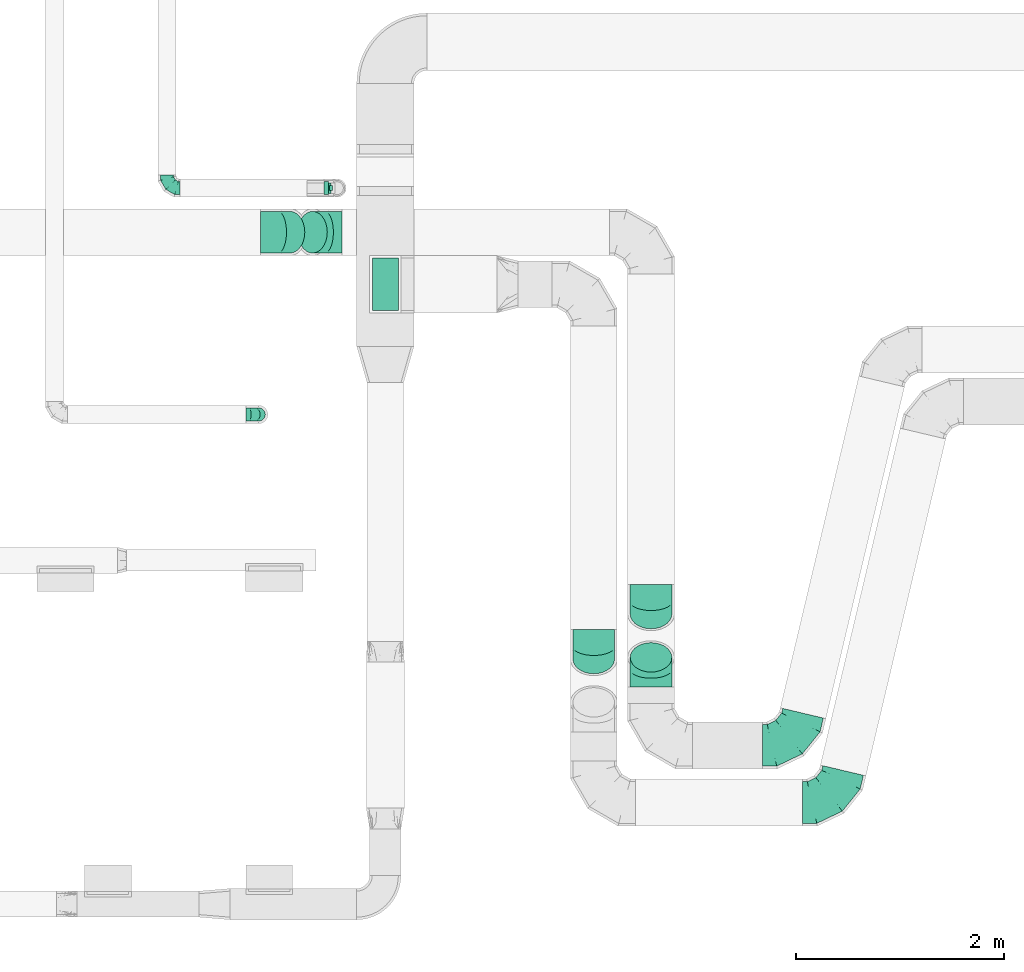
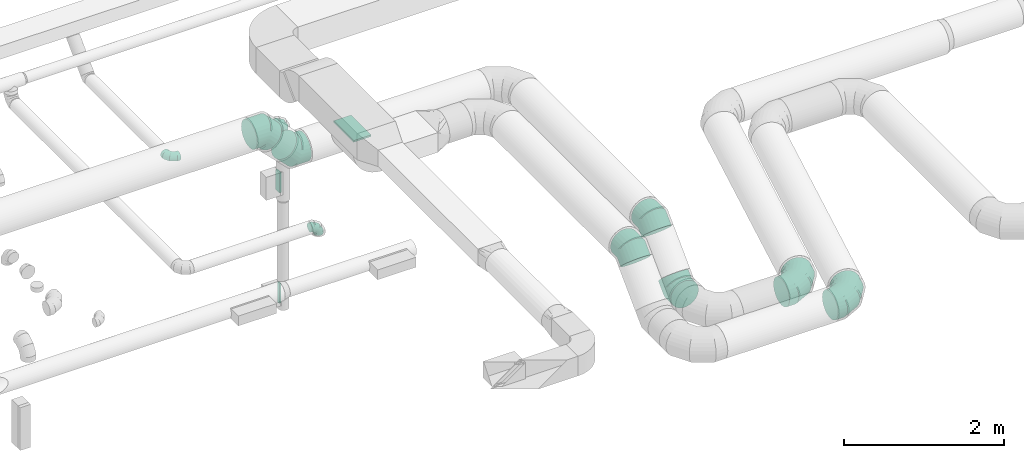
# One storey, part 53 of 97: 13 flow fittings.
"""IFC2X3 building model written with IfcOpenShell, lengths in millimetres."""

import ifcopenshell
import ifcopenshell.guid

model = None  # the IFC model being written
_history = None  # IfcOwnerHistory: only IFC2X3 demands one
_inside = {}  # id of a spatial element -> (the spatial element, [elements in it])
_under = {}  # id of a project, library or spatial element -> (it, [spatial elements below it])
_declared = {}  # id of a project -> (the project, [libraries it declares])
_typed = {}  # id of a type object -> (the type object, [elements of that type])
_made_of = {}  # id of a material, layer set ... -> (it, [elements and type objects made of it])


def new_model(schema):
    """Start an empty IFC model of exactly this schema.

    Asked for "IFC4X3", IfcOpenShell would pick the latest addendum, in which some entities
    have other attributes; the version numbers below select the first issue.
    IFC2X3 requires an IfcOwnerHistory on every rooted entity: one is made here for all.
    """
    global model, _history
    if schema == "IFC4X3":
        model = ifcopenshell.file(schema_version=(4, 3, 0, 0))
    else:
        model = ifcopenshell.file(schema=schema)
    _inside.clear()
    _under.clear()
    _declared.clear()
    _typed.clear()
    _made_of.clear()
    _history = None
    if model.schema == "IFC2X3":
        org = make("IfcOrganization", Name="unknown")
        user = make(
            "IfcPersonAndOrganization",
            ThePerson=make("IfcPerson", FamilyName="unknown"),
            TheOrganization=org,
        )
        app = make(
            "IfcApplication",
            ApplicationDeveloper=org,
            Version="unknown",
            ApplicationFullName="unknown",
            ApplicationIdentifier="unknown",
        )
        _history = make(
            "IfcOwnerHistory",
            OwningUser=user,
            OwningApplication=app,
            ChangeAction="ADDED",
            CreationDate=0,
        )
    return model


def make(cls, **values):
    """One entity of the class cls with the attributes given. An attribute that is None is left unset."""
    return model.create_entity(
        cls, **{name: value for name, value in values.items() if value is not None}
    )


def entity(cls, *values):
    """Any entity or typed value of the class cls, its attributes in the order of the schema. None: left unset."""
    e = model.create_entity(cls)
    for i, value in enumerate(values):
        if value is not None:
            e[i] = value
    return e


def rooted(cls, **values):
    """An entity with a GlobalId (a new one), such as an element, a storey or a relation."""
    return make(cls, GlobalId=ifcopenshell.guid.new(), OwnerHistory=_history, **values)


def si_unit(unit_type, name, prefix=None):
    """IfcSIUnit, for example si_unit("LENGTHUNIT", "METRE", prefix="MILLI")."""
    return make("IfcSIUnit", UnitType=unit_type, Prefix=prefix, Name=name)


def converted_unit(unit_type, name, factor, base, dimensions=None, offset=None):
    """IfcConversionBasedUnit, such as the inch: factor (a typed value) times the base unit."""
    return make(
        "IfcConversionBasedUnit"
        if offset is None
        else "IfcConversionBasedUnitWithOffset",
        ConversionOffset=offset,
        Dimensions=None
        if dimensions is None
        else entity("IfcDimensionalExponents", *dimensions),
        UnitType=unit_type,
        Name=name,
        ConversionFactor=make(
            "IfcMeasureWithUnit", ValueComponent=factor, UnitComponent=base
        ),
    )


def derived_unit(unit_type, elements):
    """IfcDerivedUnit: a product of units, each with its exponent."""
    return make(
        "IfcDerivedUnit",
        Elements=[
            make("IfcDerivedUnitElement", Unit=unit, Exponent=power)
            for unit, power in elements
        ],
        UnitType=unit_type,
    )


def assignment(units):
    """IfcUnitAssignment: the units of a project."""
    return None if units is None else make("IfcUnitAssignment", Units=units)


def point(xyz):
    """IfcCartesianPoint."""
    return None if xyz is None else make("IfcCartesianPoint", Coordinates=xyz)


def direction(xyz):
    """IfcDirection."""
    return None if xyz is None else make("IfcDirection", DirectionRatios=xyz)


def frame(location, z_axis=None, x_axis=None):
    """IfcAxis2Placement3D, a coordinate frame: its origin and axes. An axis left out is left unset."""
    return make(
        "IfcAxis2Placement3D",
        Location=point(location),
        Axis=direction(z_axis),
        RefDirection=direction(x_axis),
    )


def frame_2d(location, x_axis=None):
    """IfcAxis2Placement2D, a coordinate frame in the plane: its origin and x axis."""
    return make(
        "IfcAxis2Placement2D", Location=point(location), RefDirection=direction(x_axis)
    )


def origin():
    """The frame at (0, 0, 0) with its axes left unset."""
    return frame((0.0, 0.0, 0.0))


def origin_2d_with_axis():
    """The frame at (0, 0) in the plane with the x axis (1, 0) written out."""
    return frame_2d((0.0, 0.0), x_axis=(1.0, 0.0))


def place(relative_to, where):
    """IfcLocalPlacement: puts the frame where relative to a parent placement (None: the world)."""
    return make(
        "IfcLocalPlacement", PlacementRelTo=relative_to, RelativePlacement=where
    )


def context(
    kind, dimensions, precision=None, world=None, true_north=None, identifier=None
):
    """IfcGeometricRepresentationContext, for example the 3D "Model" context."""
    return make(
        "IfcGeometricRepresentationContext",
        ContextIdentifier=identifier,
        ContextType=kind,
        CoordinateSpaceDimension=dimensions,
        Precision=precision,
        WorldCoordinateSystem=world,
        TrueNorth=true_north,
    )


def subcontext(parent, identifier, kind, view, scale=None):
    """IfcGeometricRepresentationSubContext, for example "Body" below "Model"."""
    return make(
        "IfcGeometricRepresentationSubContext",
        ContextIdentifier=identifier,
        ContextType=kind,
        ParentContext=parent,
        TargetScale=scale,
        TargetView=view,
    )


def project(units=None, contexts=None):
    """IfcProject with its units and contexts."""
    return rooted(
        "IfcProject",
        Name="project",
        RepresentationContexts=contexts,
        UnitsInContext=assignment(units),
    )


def spatial(cls, under=None, at=None, **own):
    """A site, building, storey or space (cls), placed at a placement, below another one or the project."""
    s = rooted(cls, ObjectPlacement=at, **own)
    if under is not None:
        _under.setdefault(under.id(), (under, []))[1].append(s)
    return s


def profile(cls, at=None, kind="AREA", **sizes):
    """A parametric profile (cls). Its sizes go by their IFC names, for example OverallWidth=200.0."""
    return make(cls, ProfileType=kind, Position=at, **sizes)


def rectangle(**sizes):
    """IfcRectangleProfileDef."""
    return profile("IfcRectangleProfileDef", **sizes)


def extrude(swept, where, along, depth):
    """IfcExtrudedAreaSolid: the profile swept, set in the frame where, extruded along a direction by depth."""
    return make(
        "IfcExtrudedAreaSolid",
        SweptArea=swept,
        Position=where,
        ExtrudedDirection=direction(along),
        Depth=depth,
    )


def faces_of(points, faces, orient=None, outer=None):
    """IfcFace entities. A face is a list of loops; a loop is a list of indices into points, from 0.

    orient and outer hold one flag for each loop. By default every Orientation is true, the
    first loop of a face is its IfcFaceOuterBound and the others are IfcFaceBound.
    """
    made = []
    for i, loops in enumerate(faces):
        bounds = []
        for j, loop in enumerate(loops):
            is_outer = j == 0 if outer is None else outer[i][j]
            bounds.append(
                make(
                    "IfcFaceOuterBound" if is_outer else "IfcFaceBound",
                    Bound=make("IfcPolyLoop", Polygon=[points[k] for k in loop]),
                    Orientation=True if orient is None else orient[i][j],
                )
            )
        made.append(make("IfcFace", Bounds=bounds))
    return made


def faceted_brep(points, faces, orient=None, outer=None, voids=None):
    """IfcFacetedBrep: a solid bounded by flat faces; with voids (closed shells), ...WithVoids."""
    shared = [point(p) for p in points]
    hull = make("IfcClosedShell", CfsFaces=faces_of(shared, faces, orient, outer))
    if voids is None:
        return make("IfcFacetedBrep", Outer=hull)
    return make(
        "IfcFacetedBrepWithVoids",
        Outer=hull,
        Voids=[
            make(cls, CfsFaces=faces_of(shared, fs, o, b)) for cls, fs, o, b in voids
        ],
    )


def shape(context_of_items, identifier, shape_type, items):
    """IfcShapeRepresentation: the items that make up one representation, for example the "Body"."""
    return make(
        "IfcShapeRepresentation",
        ContextOfItems=context_of_items,
        RepresentationIdentifier=identifier,
        RepresentationType=shape_type,
        Items=items,
    )


def source(mapping_origin, context_of_items, identifier, shape_type, items):
    """IfcRepresentationMap: a shape defined once, which mapped items show again and again."""
    return make(
        "IfcRepresentationMap",
        MappingOrigin=mapping_origin,
        MappedRepresentation=shape(context_of_items, identifier, shape_type, items),
    )


def transform(
    local_origin,
    x_axis=None,
    y_axis=None,
    z_axis=None,
    scale=None,
    scale2=None,
    scale3=None,
    uniform=True,
):
    """IfcCartesianTransformationOperator3D, or its non-uniform kind. x_axis, y_axis, z_axis: its Axis1, 2, 3."""
    if uniform:
        return make(
            "IfcCartesianTransformationOperator3D",
            Axis1=direction(x_axis),
            Axis2=direction(y_axis),
            LocalOrigin=point(local_origin),
            Scale=scale,
            Axis3=direction(z_axis),
        )
    return make(
        "IfcCartesianTransformationOperator3DnonUniform",
        Axis1=direction(x_axis),
        Axis2=direction(y_axis),
        LocalOrigin=point(local_origin),
        Scale=scale,
        Axis3=direction(z_axis),
        Scale2=scale2,
        Scale3=scale3,
    )


def mapped(mapping_source, mapping_target):
    """IfcMappedItem: shows the shape of a source again, moved by a transform."""
    return make(
        "IfcMappedItem", MappingSource=mapping_source, MappingTarget=mapping_target
    )


def material(Name=None, Category=None):
    """IfcMaterial."""
    return make("IfcMaterial", Name=Name, Category=Category)


def made_of(thing, what):
    """Note that an element or type object is made of a material, layer set ...; save() writes the relation."""
    if what is not None:
        _made_of.setdefault(what.id(), (what, []))[1].append(thing)
    return thing


def type_object(cls, material=None, **own):
    """A type object (cls), such as IfcWallType, which elements share."""
    return made_of(rooted(cls, **own), material)


def type_shapes(of_type, sources):
    """Give a type object the sources (RepresentationMaps) that its elements show as mapped items."""
    of_type.RepresentationMaps = sources


def element(
    cls,
    number,
    at=None,
    inside=None,
    cuts=None,
    type_object=None,
    material=None,
    context=None,
    identifier="Body",
    shape_type=None,
    held_by="IfcProductDefinitionShape",
    body=None,
    shapes=None,
    **own,
):
    """One element of the class cls, such as IfcWall. Its Tag is "e" and its number.

    at: its placement. inside: the storey or other place that contains it. cuts: it is an
    opening in that element (IfcRelVoidsElement). A single representation is given by context,
    identifier, shape_type and body (its items); several are given by shapes. held_by: the class
    of the entity that holds the representations. save() writes the other relations.
    """
    e = rooted(cls, Tag="e%d" % number, ObjectPlacement=at, **own)
    if body is not None:
        shapes = [shape(context, identifier, shape_type, body)]
    if shapes is not None:
        e.Representation = make(held_by, Representations=shapes)
    if inside is not None:
        _inside.setdefault(inside.id(), (inside, []))[1].append(e)
    if cuts is not None:
        rooted(
            "IfcRelVoidsElement", RelatingBuildingElement=cuts, RelatedOpeningElement=e
        )
    if type_object is not None:
        _typed.setdefault(type_object.id(), (type_object, []))[1].append(e)
    return made_of(e, material)


def aggregate(whole, parts):
    """IfcRelAggregates: a whole, such as a stair, and the parts it consists of."""
    return rooted("IfcRelAggregates", RelatingObject=whole, RelatedObjects=parts)


def save(model, path):
    """Write the relations noted so far, then the file.

    IfcRelAggregates (storeys below a building ...), IfcRelContainedInSpatialStructure (elements
    in a storey), IfcRelDefinesByType, IfcRelAssociatesMaterial and IfcRelDeclares: one each for
    every whole, place, type object, material and project.
    """
    for whole, parts in _under.values():
        aggregate(whole, parts)
    for where, things in _inside.values():
        rooted(
            "IfcRelContainedInSpatialStructure",
            RelatedElements=things,
            RelatingStructure=where,
        )
    for kind, things in _typed.values():
        rooted("IfcRelDefinesByType", RelatedObjects=things, RelatingType=kind)
    for what, things in _made_of.values():
        rooted("IfcRelAssociatesMaterial", RelatedObjects=things, RelatingMaterial=what)
    for by, libraries in _declared.values():
        rooted("IfcRelDeclares", RelatingContext=by, RelatedDefinitions=libraries)
    model.write(path)


model = new_model("IFC2X3")

# Units and contexts
model_context = context("Model", 3, precision=0.01, world=origin(), true_north=direction((6.12303176911189e-17, 1.0)))
body_context = subcontext(model_context, "Body", "Model", "MODEL_VIEW")
ifc_project = project(units=[si_unit("LENGTHUNIT", "METRE", prefix="MILLI"), si_unit("AREAUNIT", "SQUARE_METRE"), si_unit("VOLUMEUNIT", "CUBIC_METRE"), converted_unit("PLANEANGLEUNIT", "DEGREE", entity("IfcRatioMeasure", 0.0174532925199433), si_unit("PLANEANGLEUNIT", "RADIAN"), dimensions=[0, 0, 0, 0, 0, 0, 0]), si_unit("MASSUNIT", "GRAM", prefix="KILO"), derived_unit("MASSDENSITYUNIT", [(si_unit("MASSUNIT", "GRAM", prefix="KILO"), 1), (si_unit("LENGTHUNIT", "METRE"), -3)]), derived_unit("MOMENTOFINERTIAUNIT", [(si_unit("LENGTHUNIT", "METRE"), 4)]), si_unit("TIMEUNIT", "SECOND"), si_unit("FREQUENCYUNIT", "HERTZ"), si_unit("THERMODYNAMICTEMPERATUREUNIT", "DEGREE_CELSIUS"), derived_unit("THERMALTRANSMITTANCEUNIT", [(si_unit("MASSUNIT", "GRAM", prefix="KILO"), 1), (si_unit("THERMODYNAMICTEMPERATUREUNIT", "KELVIN"), -1), (si_unit("TIMEUNIT", "SECOND"), -3)]), derived_unit("VOLUMETRICFLOWRATEUNIT", [(si_unit("LENGTHUNIT", "METRE"), 3), (si_unit("TIMEUNIT", "SECOND"), -1)]), derived_unit("MASSFLOWRATEUNIT", [(si_unit("MASSUNIT", "GRAM", prefix="KILO"), 1), (si_unit("TIMEUNIT", "SECOND"), -1)]), derived_unit("ROTATIONALFREQUENCYUNIT", [(si_unit("TIMEUNIT", "SECOND"), -1)]), si_unit("ELECTRICCURRENTUNIT", "AMPERE"), si_unit("ELECTRICVOLTAGEUNIT", "VOLT"), si_unit("POWERUNIT", "WATT"), si_unit("FORCEUNIT", "NEWTON", prefix="KILO"), si_unit("ILLUMINANCEUNIT", "LUX"), si_unit("LUMINOUSFLUXUNIT", "LUMEN"), si_unit("LUMINOUSINTENSITYUNIT", "CANDELA"), derived_unit("USERDEFINED", [(si_unit("MASSUNIT", "GRAM", prefix="KILO"), -1), (si_unit("LENGTHUNIT", "METRE"), -2), (si_unit("TIMEUNIT", "SECOND"), 3), (si_unit("LUMINOUSFLUXUNIT", "LUMEN"), 1)]), derived_unit("LINEARVELOCITYUNIT", [(si_unit("LENGTHUNIT", "METRE"), 1), (si_unit("TIMEUNIT", "SECOND"), -1)]), si_unit("PRESSUREUNIT", "PASCAL"), derived_unit("USERDEFINED", [(si_unit("LENGTHUNIT", "METRE"), -2), (si_unit("MASSUNIT", "GRAM", prefix="KILO"), 1), (si_unit("TIMEUNIT", "SECOND"), -2)]), derived_unit("LINEARFORCEUNIT", [(si_unit("MASSUNIT", "GRAM", prefix="KILO"), 1), (si_unit("LENGTHUNIT", "METRE"), 1), (si_unit("TIMEUNIT", "SECOND"), -2), (si_unit("LENGTHUNIT", "METRE"), -1)]), derived_unit("PLANARFORCEUNIT", [(si_unit("MASSUNIT", "GRAM", prefix="KILO"), 1), (si_unit("LENGTHUNIT", "METRE"), 1), (si_unit("TIMEUNIT", "SECOND"), -2), (si_unit("LENGTHUNIT", "METRE"), -2)])], contexts=[model_context])

# Site, building, storey
site_placement = place(None, origin())
site = spatial("IfcSite", under=ifc_project, at=site_placement, CompositionType="ELEMENT")
building_placement = place(site_placement, origin())
building = spatial("IfcBuilding", under=site, at=building_placement, CompositionType="ELEMENT")
storey_placement = place(building_placement, frame((0.0, 0.0, -4900.0)))
storey = spatial("IfcBuildingStorey", under=building, at=storey_placement, CompositionType="ELEMENT", Elevation=-4900.0)

# Flow fittings
ifc_material = material()
duct_fitting_type_1 = type_object("IfcDuctFittingType", PredefinedType="NOTDEFINED", material=ifc_material)
shared_shape_1 = source(origin(), body_context, "Body", "SweptSolid", [
    extrude(rectangle(XDim=26.0960000001476, YDim=300.0, at=origin_2d_with_axis()), frame((6.95, 0.0, -50.0)), (0.0, 0.0, 1.0), 100.0),
])
type_shapes(duct_fitting_type_1, [shared_shape_1])
flow_fitting_1_placement = place(storey_placement, frame((48936.88, 7146.24, 2850.0), z_axis=(0.0, 1.0, 0.0), x_axis=(-1.0, 0.0, 0.0)))
element("IfcFlowFitting", 1, at=flow_fitting_1_placement, inside=storey, type_object=duct_fitting_type_1, material=ifc_material, context=body_context, shape_type="MappedRepresentation", body=[
    mapped(shared_shape_1, transform((0.0, 0.0, 0.0), scale=1.0)),
])
duct_fitting_type_2 = type_object("IfcDuctFittingType", PredefinedType="NOTDEFINED", material=ifc_material)
shared_shape_2 = source(origin(), body_context, "Body", "SweptSolid", [
    extrude(rectangle(XDim=250.0, YDim=26.0960000001597, at=origin_2d_with_axis()), frame((6.95, 0.0, -250.0), z_axis=(0.0, 0.0, 1.0), x_axis=(0.0, -1.0, 0.0)), (0.0, 0.0, 1.0), 500.0),
])
type_shapes(duct_fitting_type_2, [shared_shape_2])
flow_fitting_2_placement = place(storey_placement, frame((49463.6, 6223.55, 4025.0), z_axis=(0.0, -1.0, 0.0), x_axis=(0.0, 0.0, -1.0)))
element("IfcFlowFitting", 2, at=flow_fitting_2_placement, inside=storey, type_object=duct_fitting_type_2, material=ifc_material, context=body_context, shape_type="MappedRepresentation", body=[
    mapped(shared_shape_2, transform((0.0, 0.0, 0.0), scale=1.0)),
])
duct_fitting_type_3 = type_object("IfcDuctFittingType", PredefinedType="NOTDEFINED", material=ifc_material)
shared_shape_3 = source(origin(), body_context, "Body", "SweptSolid", [
    extrude(rectangle(XDim=26.0960000000091, YDim=300.0, at=origin_2d_with_axis()), frame((6.95, 0.0, -25.0)), (0.0, 0.0, 1.0), 50.0),
])
type_shapes(duct_fitting_type_3, [shared_shape_3])
flow_fitting_3_placement = place(storey_placement, frame((48949.38, 7146.24, 1150.0), z_axis=(0.0, 1.0, 0.0), x_axis=(-1.0, 0.0, 0.0)))
element("IfcFlowFitting", 3, at=flow_fitting_3_placement, inside=storey, type_object=duct_fitting_type_3, material=ifc_material, context=body_context, shape_type="MappedRepresentation", body=[
    mapped(shared_shape_3, transform((0.0, 0.0, 0.0), scale=1.0)),
])
duct_fitting_type_4 = type_object("IfcDuctFittingType", PredefinedType="NOTDEFINED", material=ifc_material)
shared_shape_4 = source(origin(), body_context, "Body", "Brep", [
    faceted_brep([(-125.0, 0.0, -62.5), (-125.0, -16.18, -60.37), (-125.0, -31.25, -54.13), (-125.0, -44.19, -44.19), (-125.0, -54.13, -31.25), (-125.0, -60.37, -16.18), (-125.0, -62.5, 0.0), (-125.0, -60.37, 16.18), (-125.0, -54.13, 31.25), (-125.0, -44.19, 44.19), (-125.0, -31.25, 54.13), (-125.0, -16.18, 60.37), (-125.0, 0.0, 62.5), (-125.0, 16.18, 60.37), (-125.0, 31.25, 54.13), (-125.0, 44.19, 44.19), (-125.0, 54.13, 31.25), (-125.0, 60.37, 16.18), (-125.0, 62.5, 0.0), (-125.0, 60.37, -16.18), (-125.0, 54.13, -31.25), (-125.0, 44.19, -44.19), (-125.0, 31.25, -54.13), (-125.0, 16.18, -60.37), (-95.84, 16.18, 60.37), (-99.88, 31.25, 54.13), (-91.51, 0.0, 62.5), (-103.35, 44.19, 44.19), (-107.68, 60.37, 16.18), (-108.25, 62.5, 0.0), (-106.01, 54.13, 31.25), (-106.01, 54.13, -31.25), (-103.35, 44.19, -44.19), (-107.68, 60.37, -16.18), (-95.84, 16.18, -60.37), (-91.51, 0.0, -62.5), (-99.88, 31.25, -54.13), (-87.17, -16.18, -60.37), (-83.13, -31.25, -54.13), (-79.66, -44.19, -44.19), (-77.0, -54.13, -31.25), (-75.33, -60.37, -16.18), (-74.76, -62.5, 0.0), (-75.33, -60.37, 16.18), (-77.0, -54.13, 31.25), (-79.66, -44.19, 44.19), (-83.13, -31.25, 54.13), (-87.17, -16.18, 60.37), (-45.34, 45.34, 60.37), (-56.37, 56.37, 54.13), (-33.49, 33.49, 62.5), (-65.85, 65.85, 44.19), (-73.12, 73.12, 31.25), (-77.69, 77.69, 16.18), (-79.25, 79.25, 0.0), (-77.69, 77.69, -16.18), (-73.12, 73.12, -31.25), (-65.85, 65.85, -44.19), (-45.34, 45.34, -60.37), (-33.49, 33.49, -62.5), (-56.37, 56.37, -54.13), (-21.65, 21.65, -60.37), (-10.62, 10.62, -54.13), (-1.14, 1.14, -44.19), (6.13, -6.13, -31.25), (10.7, -10.7, -16.18), (12.26, -12.26, 0.0), (10.7, -10.7, 16.18), (6.13, -6.13, 31.25), (-1.14, 1.14, 44.19), (-10.62, 10.62, 54.13), (-21.65, 21.65, 60.37), (-16.18, 95.84, 60.37), (-31.25, 99.88, 54.13), (0.0, 91.51, 62.5), (-44.19, 103.35, 44.19), (-54.13, 106.01, 31.25), (-60.37, 107.68, 16.18), (-62.5, 108.25, 0.0), (-60.37, 107.68, -16.18), (-54.13, 106.01, -31.25), (-44.19, 103.35, -44.19), (-16.18, 95.84, -60.37), (0.0, 91.51, -62.5), (-31.25, 99.88, -54.13), (16.18, 87.17, -60.37), (31.25, 83.13, -54.13), (44.19, 79.66, -44.19), (54.13, 77.0, -31.25), (60.37, 75.33, -16.18), (62.5, 74.76, 0.0), (60.37, 75.33, 16.18), (54.13, 77.0, 31.25), (44.19, 79.66, 44.19), (31.25, 83.13, 54.13), (16.18, 87.17, 60.37), (-16.18, 125.0, -60.37), (-31.25, 125.0, -54.13), (-44.19, 125.0, -44.19), (-54.13, 125.0, -31.25), (-60.37, 125.0, -16.18), (-62.5, 125.0, 0.0), (-60.37, 125.0, 16.18), (-54.13, 125.0, 31.25), (-44.19, 125.0, 44.19), (-31.25, 125.0, 54.13), (-16.18, 125.0, 60.37), (0.0, 125.0, 62.5), (16.18, 125.0, 60.37), (31.25, 125.0, 54.13), (44.19, 125.0, 44.19), (54.13, 125.0, 31.25), (60.37, 125.0, 16.18), (62.5, 125.0, 0.0), (60.37, 125.0, -16.18), (54.13, 125.0, -31.25), (44.19, 125.0, -44.19), (31.25, 125.0, -54.13), (16.18, 125.0, -60.37), (0.0, 125.0, -62.5)], [[[0, 1, 2, 3, 4, 5, 6, 7, 8, 9, 10, 11, 12, 13, 14, 15, 16, 17, 18, 19, 20, 21, 22, 23]], [[24, 25, 14, 13]], [[26, 24, 13, 12]], [[14, 25, 27, 15]], [[28, 29, 18, 17]], [[30, 28, 17, 16]], [[15, 27, 30, 16]], [[20, 31, 32, 21]], [[33, 31, 20, 19]], [[18, 29, 33, 19]], [[34, 35, 0, 23]], [[36, 34, 23, 22]], [[21, 32, 36, 22]], [[1, 0, 35, 37]], [[2, 1, 37, 38]], [[38, 39, 3, 2]], [[5, 4, 40, 41]], [[6, 5, 41, 42]], [[39, 40, 4, 3]], [[6, 42, 43, 7]], [[7, 43, 44, 8]], [[45, 9, 8, 44]], [[9, 45, 46, 10]], [[10, 46, 47, 11]], [[26, 12, 11, 47]], [[48, 49, 25, 24]], [[50, 48, 24, 26]], [[27, 25, 49, 51]], [[52, 53, 28, 30]], [[51, 52, 30, 27]], [[29, 28, 53, 54]], [[55, 56, 31, 33]], [[54, 55, 33, 29]], [[57, 32, 31, 56]], [[58, 59, 35, 34]], [[60, 58, 34, 36]], [[57, 60, 36, 32]], [[37, 35, 59, 61]], [[38, 37, 61, 62]], [[39, 38, 62, 63]], [[41, 40, 64, 65]], [[42, 41, 65, 66]], [[63, 64, 40, 39]], [[43, 42, 66, 67]], [[44, 43, 67, 68]], [[68, 69, 45, 44]], [[46, 45, 69, 70]], [[47, 46, 70, 71]], [[26, 47, 71, 50]], [[72, 73, 49, 48]], [[74, 72, 48, 50]], [[51, 49, 73, 75]], [[76, 77, 53, 52]], [[75, 76, 52, 51]], [[54, 53, 77, 78]], [[79, 80, 56, 55]], [[78, 79, 55, 54]], [[81, 57, 56, 80]], [[82, 83, 59, 58]], [[84, 82, 58, 60]], [[81, 84, 60, 57]], [[61, 59, 83, 85]], [[62, 61, 85, 86]], [[63, 62, 86, 87]], [[65, 64, 88, 89]], [[66, 65, 89, 90]], [[87, 88, 64, 63]], [[67, 66, 90, 91]], [[68, 67, 91, 92]], [[92, 93, 69, 68]], [[70, 69, 93, 94]], [[71, 70, 94, 95]], [[50, 71, 95, 74]], [[96, 97, 98, 99, 100, 101, 102, 103, 104, 105, 106, 107, 108, 109, 110, 111, 112, 113, 114, 115, 116, 117, 118, 119]], [[72, 74, 107, 106]], [[73, 72, 106, 105]], [[75, 73, 105, 104]], [[77, 76, 103, 102]], [[78, 77, 102, 101]], [[75, 104, 103, 76]], [[78, 101, 100, 79]], [[79, 100, 99, 80]], [[80, 99, 98, 81]], [[96, 119, 83, 82]], [[97, 96, 82, 84]], [[84, 81, 98, 97]], [[83, 119, 118, 85]], [[85, 118, 117, 86]], [[116, 87, 86, 117]], [[88, 115, 114, 89]], [[89, 114, 113, 90]], [[115, 88, 87, 116]], [[91, 90, 113, 112]], [[92, 91, 112, 111]], [[111, 110, 93, 92]], [[95, 94, 109, 108]], [[74, 95, 108, 107]], [[110, 109, 94, 93]]]),
])
type_shapes(duct_fitting_type_4, [shared_shape_4])
for number, where, z_axis, x_axis in (
    (4, (48999.38, 7146.24, 3740.0), (0.0, 1.0, 0.0), (1.0, 0.0, 0.0)),
    (5, (48249.39, 4973.33, 3740.0), (0.0, -1.0, 0.0), (0.0, 0.0, 1.0)),
    (6, (47368.94, 7146.24, 3740.0), (0.0, 0.0, 1.0), (0.0, -1.0, 0.0)),
):
    element("IfcFlowFitting", number, at=place(storey_placement, frame(where, z_axis=z_axis, x_axis=x_axis)), inside=storey, type_object=duct_fitting_type_4, material=ifc_material, context=body_context, shape_type="MappedRepresentation", body=[
        mapped(shared_shape_4, transform((0.0, 0.0, 0.0), scale=1.0)),
    ])
duct_fitting_type_5 = type_object("IfcDuctFittingType", PredefinedType="NOTDEFINED", material=ifc_material)
shared_shape_5 = source(origin(), body_context, "Body", "Brep", [
    faceted_brep([(-165.69, 0.0, -200.0), (-165.69, -44.5, -194.99), (-165.69, -86.78, -180.19), (-165.69, -124.7, -156.37), (-165.69, -156.37, -124.7), (-165.69, -180.19, -86.78), (-165.69, -194.99, -44.5), (-165.69, -200.0, 0.0), (-165.69, -194.99, 44.5), (-165.69, -180.19, 86.78), (-165.69, -156.37, 124.7), (-165.69, -124.7, 156.37), (-165.69, -86.78, 180.19), (-165.69, -44.5, 194.99), (-165.69, 0.0, 200.0), (-165.69, 44.5, 194.99), (-165.69, 86.78, 180.19), (-165.69, 124.7, 156.37), (-165.69, 156.37, 124.7), (-165.69, 180.19, 86.78), (-165.69, 194.99, 44.5), (-165.69, 200.0, 0.0), (-165.69, 194.99, -44.5), (-165.69, 180.19, -86.78), (-165.69, 156.37, -124.7), (-165.69, 124.7, -156.37), (-165.69, 86.78, -180.19), (-165.69, 44.5, -194.99), (0.0, 0.0, 200.0), (-18.43, 44.5, 194.99), (-35.94, 86.78, 180.19), (-51.65, 124.7, 156.37), (-64.77, 156.37, 124.7), (-74.64, 180.19, 86.78), (-80.77, 194.99, 44.5), (-82.84, 200.0, 0.0), (-80.77, 194.99, -44.5), (-74.64, 180.19, -86.78), (-64.77, 156.37, -124.7), (-51.65, 124.7, -156.37), (-35.94, 86.78, -180.19), (-18.43, 44.5, -194.99), (0.0, 0.0, -200.0), (18.43, -44.5, -194.99), (35.94, -86.78, -180.19), (51.65, -124.7, -156.37), (64.77, -156.37, -124.7), (74.64, -180.19, -86.78), (80.77, -194.99, -44.5), (82.84, -200.0, 0.0), (80.77, -194.99, 44.5), (74.64, -180.19, 86.78), (64.77, -156.37, 124.7), (51.65, -124.7, 156.37), (35.94, -86.78, 180.19), (18.43, -44.5, 194.99), (117.16, 117.16, 200.0), (85.69, 148.63, 194.99), (55.8, 178.52, 180.19), (28.98, 205.33, 156.37), (6.59, 227.72, 124.7), (-10.26, 244.57, 86.78), (-20.72, 255.03, 44.5), (-24.26, 258.58, 0.0), (-20.72, 255.03, -44.5), (-10.26, 244.57, -86.78), (6.59, 227.72, -124.7), (28.98, 205.33, -156.37), (55.8, 178.52, -180.19), (85.69, 148.63, -194.99), (117.16, 117.16, -200.0), (148.63, 85.69, -194.99), (178.52, 55.8, -180.19), (205.33, 28.98, -156.37), (227.72, 6.59, -124.7), (244.57, -10.26, -86.78), (255.03, -20.72, -44.5), (258.58, -24.26, 0.0), (255.03, -20.72, 44.5), (244.57, -10.26, 86.78), (227.72, 6.59, 124.7), (205.33, 28.98, 156.37), (178.52, 55.8, 180.19), (148.63, 85.69, 194.99)], [[[0, 1, 2, 3, 4, 5, 6, 7, 8, 9, 10, 11, 12, 13, 14, 15, 16, 17, 18, 19, 20, 21, 22, 23, 24, 25, 26, 27]], [[28, 29, 15, 14]], [[30, 31, 17, 16]], [[29, 30, 16, 15]], [[31, 32, 18, 17]], [[32, 33, 19, 18]], [[34, 35, 21, 20]], [[33, 34, 20, 19]], [[35, 36, 22, 21]], [[37, 38, 24, 23]], [[36, 37, 23, 22]], [[38, 39, 25, 24]], [[39, 40, 26, 25]], [[41, 42, 0, 27]], [[40, 41, 27, 26]], [[1, 0, 42, 43]], [[43, 44, 2, 1]], [[45, 3, 2, 44]], [[45, 46, 4, 3]], [[5, 4, 46, 47]], [[47, 48, 6, 5]], [[49, 7, 6, 48]], [[7, 49, 50, 8]], [[8, 50, 51, 9]], [[9, 51, 52, 10]], [[52, 53, 11, 10]], [[11, 53, 54, 12]], [[12, 54, 55, 13]], [[13, 55, 28, 14]], [[29, 28, 56, 57]], [[30, 29, 57, 58]], [[31, 30, 58, 59]], [[59, 60, 32, 31]], [[33, 32, 60, 61]], [[34, 33, 61, 62]], [[35, 34, 62, 63]], [[63, 64, 36, 35]], [[65, 66, 38, 37]], [[64, 65, 37, 36]], [[66, 67, 39, 38]], [[39, 67, 68, 40]], [[40, 68, 69, 41]], [[41, 69, 70, 42]], [[42, 70, 71, 43]], [[43, 71, 72, 44]], [[44, 72, 73, 45]], [[73, 74, 46, 45]], [[46, 74, 75, 47]], [[47, 75, 76, 48]], [[48, 76, 77, 49]], [[50, 49, 77, 78]], [[51, 50, 78, 79]], [[52, 51, 79, 80]], [[80, 81, 53, 52]], [[54, 53, 81, 82]], [[55, 54, 82, 83]], [[28, 55, 83, 56]], [[69, 68, 67, 66, 65, 64, 63, 62, 61, 60, 59, 58, 57, 56, 83, 82, 81, 80, 79, 78, 77, 76, 75, 74, 73, 72, 71, 70]]]),
])
type_shapes(duct_fitting_type_5, [shared_shape_5])
for number, where, z_axis, x_axis in (
    (7, (52014.1, 3175.13, 3600.0), (1.0, 0.0, 0.0), (0.0, -1.0, 0.0)),
    (8, (52014.1, 2525.13, 2950.0), (-1.0, 0.0, 0.0), (0.0, -0.707106781186522, -0.707106781186573)),
    (9, (51464.16, 2743.55, 3600.0), (1.0, 0.0, 0.0), (0.0, -1.0, 0.0)),
    (10, (48432.38, 6723.09, 4050.0), (0.0, 1.0, 0.0), (1.0, 0.0, 0.0)),
    (11, (48882.38, 6723.09, 3600.0), (0.0, -1.0, 0.0), (0.707106781186526, 0.0, -0.707106781186569)),
):
    element("IfcFlowFitting", number, at=place(storey_placement, frame(where, z_axis=z_axis, x_axis=x_axis)), inside=storey, type_object=duct_fitting_type_5, material=ifc_material, context=body_context, shape_type="MappedRepresentation", body=[
        mapped(shared_shape_5, transform((0.0, 0.0, 0.0), scale=1.0)),
    ])
duct_fitting_type_6 = type_object("IfcDuctFittingType", PredefinedType="NOTDEFINED", material=ifc_material)
shared_shape_6 = source(origin(), body_context, "Body", "Brep", [
    faceted_brep([(-316.33, 0.0, -200.0), (-316.33, -44.5, -194.99), (-316.33, -86.78, -180.19), (-316.33, -124.7, -156.37), (-316.33, -156.37, -124.7), (-316.33, -180.19, -86.78), (-316.33, -194.99, -44.5), (-316.33, -200.0, 0.0), (-316.33, -194.99, 44.5), (-316.33, -180.19, 86.78), (-316.33, -156.37, 124.7), (-316.33, -124.7, 156.37), (-316.33, -86.78, 180.19), (-316.33, -44.5, 194.99), (-316.33, 0.0, 200.0), (-316.33, 44.5, 194.99), (-316.33, 86.78, 180.19), (-316.33, 124.7, 156.37), (-316.33, 156.37, 124.7), (-316.33, 180.19, 86.78), (-316.33, 194.99, 44.5), (-316.33, 200.0, 0.0), (-316.33, 194.99, -44.5), (-316.33, 180.19, -86.78), (-316.33, 156.37, -124.7), (-316.33, 124.7, -156.37), (-316.33, 86.78, -180.19), (-316.33, 44.5, -194.99), (-225.6, 0.0, 200.0), (-235.7, 44.5, 194.99), (-245.29, 86.78, 180.19), (-253.89, 124.7, 156.37), (-261.07, 156.37, 124.7), (-266.47, 180.19, 86.78), (-269.83, 194.99, 44.5), (-270.97, 200.0, 0.0), (-269.83, 194.99, -44.5), (-266.47, 180.19, -86.78), (-261.07, 156.37, -124.7), (-253.89, 124.7, -156.37), (-245.29, 86.78, -180.19), (-235.7, 44.5, -194.99), (-225.6, 0.0, -200.0), (-215.51, -44.5, -194.99), (-205.92, -86.78, -180.19), (-197.32, -124.7, -156.37), (-190.14, -156.37, -124.7), (-184.73, -180.19, -86.78), (-181.38, -194.99, -44.5), (-180.24, -200.0, 0.0), (-181.38, -194.99, 44.5), (-184.73, -180.19, 86.78), (-190.14, -156.37, 124.7), (-197.32, -124.7, 156.37), (-205.92, -86.78, 180.19), (-215.51, -44.5, 194.99), (-61.91, 78.28, 200.0), (-90.22, 114.08, 194.99), (-117.1, 148.08, 180.19), (-141.22, 178.58, 156.37), (-161.37, 204.05, 124.7), (-176.52, 223.21, 86.78), (-185.93, 235.11, 44.5), (-189.12, 239.14, 0.0), (-185.93, 235.11, -44.5), (-176.52, 223.21, -86.78), (-161.37, 204.05, -124.7), (-141.22, 178.58, -156.37), (-117.1, 148.08, -180.19), (-90.22, 114.08, -194.99), (-61.91, 78.28, -200.0), (-33.6, 42.49, -194.99), (-6.71, 8.49, -180.19), (17.41, -22.01, -156.37), (37.55, -47.48, -124.7), (52.7, -66.64, -86.78), (62.11, -78.54, -44.5), (65.3, -82.57, 0.0), (62.11, -78.54, 44.5), (52.7, -66.64, 86.78), (37.55, -47.48, 124.7), (17.41, -22.01, 156.37), (-6.71, 8.49, 180.19), (-33.6, 42.49, 194.99), (51.99, 219.53, 200.0), (11.01, 239.61, 194.99), (-27.91, 258.68, 180.19), (-62.83, 275.79, 156.37), (-91.99, 290.08, 124.7), (-113.93, 300.83, 86.78), (-127.55, 307.5, 44.5), (-132.17, 309.77, 0.0), (-127.55, 307.5, -44.5), (-113.93, 300.83, -86.78), (-91.99, 290.08, -124.7), (-62.83, 275.79, -156.37), (-27.91, 258.68, -180.19), (11.01, 239.61, -194.99), (51.99, 219.53, -200.0), (92.97, 199.45, -194.99), (131.9, 180.38, -180.19), (166.82, 163.27, -156.37), (195.98, 148.98, -124.7), (217.92, 138.23, -86.78), (231.54, 131.56, -44.5), (236.16, 129.3, 0.0), (231.54, 131.56, 44.5), (217.92, 138.23, 86.78), (195.98, 148.98, 124.7), (166.82, 163.27, 156.37), (131.9, 180.38, 180.19), (92.97, 199.45, 194.99), (-121.71, 353.91, 0.0), (-116.83, 352.75, 44.5), (-102.44, 349.34, 86.78), (-79.25, 343.85, 124.7), (-48.44, 336.55, 156.37), (-11.54, 327.81, 180.19), (29.6, 318.07, 194.99), (72.9, 307.81, 200.0), (116.21, 297.56, 194.99), (157.34, 287.81, 180.19), (194.24, 279.07, 156.37), (225.06, 271.78, 124.7), (248.25, 266.28, 86.78), (262.64, 262.88, 44.5), (267.52, 261.72, 0.0), (262.64, 262.88, -44.5), (248.25, 266.28, -86.78), (225.06, 271.78, -124.7), (194.24, 279.07, -156.37), (157.34, 287.81, -180.19), (116.21, 297.56, -194.99), (72.9, 307.81, -200.0), (29.6, 318.07, -194.99), (-11.54, 327.81, -180.19), (-48.44, 336.55, -156.37), (-79.25, 343.85, -124.7), (-102.44, 349.34, -86.78), (-116.83, 352.75, -44.5)], [[[0, 1, 2, 3, 4, 5, 6, 7, 8, 9, 10, 11, 12, 13, 14, 15, 16, 17, 18, 19, 20, 21, 22, 23, 24, 25, 26, 27]], [[28, 29, 15, 14]], [[30, 31, 17, 16]], [[29, 30, 16, 15]], [[31, 32, 18, 17]], [[32, 33, 19, 18]], [[34, 35, 21, 20]], [[33, 34, 20, 19]], [[35, 36, 22, 21]], [[37, 38, 24, 23]], [[36, 37, 23, 22]], [[38, 39, 25, 24]], [[39, 40, 26, 25]], [[41, 42, 0, 27]], [[40, 41, 27, 26]], [[1, 0, 42, 43]], [[43, 44, 2, 1]], [[45, 3, 2, 44]], [[45, 46, 4, 3]], [[5, 4, 46, 47]], [[47, 48, 6, 5]], [[49, 7, 6, 48]], [[7, 49, 50, 8]], [[8, 50, 51, 9]], [[9, 51, 52, 10]], [[52, 53, 11, 10]], [[11, 53, 54, 12]], [[12, 54, 55, 13]], [[13, 55, 28, 14]], [[56, 57, 29, 28]], [[58, 59, 31, 30]], [[57, 58, 30, 29]], [[59, 60, 32, 31]], [[60, 61, 33, 32]], [[62, 63, 35, 34]], [[61, 62, 34, 33]], [[63, 64, 36, 35]], [[65, 66, 38, 37]], [[64, 65, 37, 36]], [[66, 67, 39, 38]], [[67, 68, 40, 39]], [[69, 70, 42, 41]], [[68, 69, 41, 40]], [[43, 42, 70, 71]], [[71, 72, 44, 43]], [[73, 45, 44, 72]], [[73, 74, 46, 45]], [[47, 46, 74, 75]], [[75, 76, 48, 47]], [[77, 49, 48, 76]], [[50, 49, 77, 78]], [[51, 50, 78, 79]], [[52, 51, 79, 80]], [[80, 81, 53, 52]], [[54, 53, 81, 82]], [[55, 54, 82, 83]], [[28, 55, 83, 56]], [[84, 85, 57, 56]], [[86, 87, 59, 58]], [[85, 86, 58, 57]], [[87, 88, 60, 59]], [[88, 89, 61, 60]], [[90, 91, 63, 62]], [[89, 90, 62, 61]], [[91, 92, 64, 63]], [[93, 94, 66, 65]], [[92, 93, 65, 64]], [[94, 95, 67, 66]], [[95, 96, 68, 67]], [[97, 98, 70, 69]], [[96, 97, 69, 68]], [[71, 70, 98, 99]], [[99, 100, 72, 71]], [[101, 73, 72, 100]], [[101, 102, 74, 73]], [[75, 74, 102, 103]], [[103, 104, 76, 75]], [[105, 77, 76, 104]], [[78, 77, 105, 106]], [[79, 78, 106, 107]], [[80, 79, 107, 108]], [[108, 109, 81, 80]], [[82, 81, 109, 110]], [[83, 82, 110, 111]], [[56, 83, 111, 84]], [[112, 113, 114, 115, 116, 117, 118, 119, 120, 121, 122, 123, 124, 125, 126, 127, 128, 129, 130, 131, 132, 133, 134, 135, 136, 137, 138, 139]], [[85, 84, 119, 118]], [[117, 116, 87, 86]], [[86, 85, 118, 117]], [[116, 115, 88, 87]], [[89, 88, 115, 114]], [[90, 89, 114, 113]], [[91, 90, 113, 112]], [[91, 112, 139, 92]], [[139, 138, 93, 92]], [[137, 94, 93, 138]], [[137, 136, 95, 94]], [[95, 136, 135, 96]], [[96, 135, 134, 97]], [[97, 134, 133, 98]], [[98, 133, 132, 99]], [[99, 132, 131, 100]], [[100, 131, 130, 101]], [[130, 129, 102, 101]], [[102, 129, 128, 103]], [[103, 128, 127, 104]], [[104, 127, 126, 105]], [[106, 105, 126, 125]], [[107, 106, 125, 124]], [[108, 107, 124, 123]], [[123, 122, 109, 108]], [[110, 109, 122, 121]], [[111, 110, 121, 120]], [[84, 111, 120, 119]]]),
])
type_shapes(duct_fitting_type_6, [shared_shape_6])
flow_fitting_4_placement = place(storey_placement, frame((53400.47, 1798.23, 2950.0)))
element("IfcFlowFitting", 12, at=flow_fitting_4_placement, inside=storey, type_object=duct_fitting_type_6, material=ifc_material, context=body_context, shape_type="MappedRepresentation", body=[
    mapped(shared_shape_6, transform((0.0, 0.0, 0.0), scale=1.0)),
])
duct_fitting_type_7 = type_object("IfcDuctFittingType", PredefinedType="NOTDEFINED", material=ifc_material)
shared_shape_7 = source(origin(), body_context, "Body", "Brep", [
    faceted_brep([(-316.33, 0.0, -200.0), (-316.33, -44.5, -194.99), (-316.33, -86.78, -180.19), (-316.33, -124.7, -156.37), (-316.33, -156.37, -124.7), (-316.33, -180.19, -86.78), (-316.33, -194.99, -44.5), (-316.33, -200.0, 0.0), (-316.33, -194.99, 44.5), (-316.33, -180.19, 86.78), (-316.33, -156.37, 124.7), (-316.33, -124.7, 156.37), (-316.33, -86.78, 180.19), (-316.33, -44.5, 194.99), (-316.33, 0.0, 200.0), (-316.33, 44.5, 194.99), (-316.33, 86.78, 180.19), (-316.33, 124.7, 156.37), (-316.33, 156.37, 124.7), (-316.33, 180.19, 86.78), (-316.33, 194.99, 44.5), (-316.33, 200.0, 0.0), (-316.33, 194.99, -44.5), (-316.33, 180.19, -86.78), (-316.33, 156.37, -124.7), (-316.33, 124.7, -156.37), (-316.33, 86.78, -180.19), (-316.33, 44.5, -194.99), (-225.6, 0.0, 200.0), (-235.7, 44.5, 194.99), (-245.29, 86.78, 180.19), (-253.89, 124.7, 156.37), (-261.07, 156.37, 124.7), (-266.47, 180.19, 86.78), (-269.83, 194.99, 44.5), (-270.97, 200.0, 0.0), (-269.83, 194.99, -44.5), (-266.47, 180.19, -86.78), (-261.07, 156.37, -124.7), (-253.89, 124.7, -156.37), (-245.29, 86.78, -180.19), (-235.7, 44.5, -194.99), (-225.6, 0.0, -200.0), (-215.51, -44.5, -194.99), (-205.92, -86.78, -180.19), (-197.32, -124.7, -156.37), (-190.14, -156.37, -124.7), (-184.73, -180.19, -86.78), (-181.38, -194.99, -44.5), (-180.24, -200.0, 0.0), (-181.38, -194.99, 44.5), (-184.73, -180.19, 86.78), (-190.14, -156.37, 124.7), (-197.32, -124.7, 156.37), (-205.92, -86.78, 180.19), (-215.51, -44.5, 194.99), (-61.91, 78.28, 200.0), (-90.22, 114.08, 194.99), (-117.1, 148.08, 180.19), (-141.22, 178.58, 156.37), (-161.37, 204.05, 124.7), (-176.52, 223.21, 86.78), (-185.93, 235.11, 44.5), (-189.12, 239.14, 0.0), (-185.93, 235.11, -44.5), (-176.52, 223.21, -86.78), (-161.37, 204.05, -124.7), (-141.22, 178.58, -156.37), (-117.1, 148.08, -180.19), (-90.22, 114.08, -194.99), (-61.91, 78.28, -200.0), (-33.6, 42.49, -194.99), (-6.71, 8.49, -180.19), (17.41, -22.01, -156.37), (37.55, -47.48, -124.7), (52.7, -66.64, -86.78), (62.11, -78.54, -44.5), (65.3, -82.57, 0.0), (62.11, -78.54, 44.5), (52.7, -66.64, 86.78), (37.55, -47.48, 124.7), (17.41, -22.01, 156.37), (-6.71, 8.49, 180.19), (-33.6, 42.49, 194.99), (51.99, 219.53, 200.0), (11.01, 239.61, 194.99), (-27.91, 258.68, 180.19), (-62.83, 275.79, 156.37), (-91.99, 290.08, 124.7), (-113.93, 300.83, 86.78), (-127.55, 307.5, 44.5), (-132.17, 309.77, 0.0), (-127.55, 307.5, -44.5), (-113.93, 300.83, -86.78), (-91.99, 290.08, -124.7), (-62.83, 275.79, -156.37), (-27.91, 258.68, -180.19), (11.01, 239.61, -194.99), (51.99, 219.53, -200.0), (92.97, 199.45, -194.99), (131.9, 180.38, -180.19), (166.82, 163.27, -156.37), (195.98, 148.98, -124.7), (217.92, 138.23, -86.78), (231.54, 131.56, -44.5), (236.16, 129.3, 0.0), (231.54, 131.56, 44.5), (217.92, 138.23, 86.78), (195.98, 148.98, 124.7), (166.82, 163.27, 156.37), (131.9, 180.38, 180.19), (92.97, 199.45, 194.99), (-116.83, 352.75, 44.5), (-102.44, 349.34, 86.78), (-79.25, 343.85, 124.7), (-48.44, 336.55, 156.37), (-11.54, 327.81, 180.19), (29.6, 318.07, 194.99), (72.9, 307.81, 200.0), (116.21, 297.56, 194.99), (157.34, 287.81, 180.19), (194.24, 279.07, 156.37), (225.06, 271.78, 124.7), (248.25, 266.28, 86.78), (262.64, 262.88, 44.5), (267.52, 261.72, 0.0), (262.64, 262.88, -44.5), (248.25, 266.28, -86.78), (225.06, 271.78, -124.7), (194.24, 279.07, -156.37), (157.34, 287.81, -180.19), (116.21, 297.56, -194.99), (72.9, 307.81, -200.0), (29.6, 318.07, -194.99), (-11.54, 327.81, -180.19), (-48.44, 336.55, -156.37), (-79.25, 343.85, -124.7), (-102.44, 349.34, -86.78), (-116.83, 352.75, -44.5), (-121.71, 353.91, 0.0)], [[[0, 1, 2, 3, 4, 5, 6, 7, 8, 9, 10, 11, 12, 13, 14, 15, 16, 17, 18, 19, 20, 21, 22, 23, 24, 25, 26, 27]], [[28, 29, 15, 14]], [[30, 31, 17, 16]], [[29, 30, 16, 15]], [[31, 32, 18, 17]], [[32, 33, 19, 18]], [[34, 35, 21, 20]], [[33, 34, 20, 19]], [[35, 36, 22, 21]], [[37, 38, 24, 23]], [[36, 37, 23, 22]], [[38, 39, 25, 24]], [[39, 40, 26, 25]], [[41, 42, 0, 27]], [[40, 41, 27, 26]], [[1, 0, 42, 43]], [[43, 44, 2, 1]], [[45, 3, 2, 44]], [[45, 46, 4, 3]], [[5, 4, 46, 47]], [[47, 48, 6, 5]], [[49, 7, 6, 48]], [[7, 49, 50, 8]], [[8, 50, 51, 9]], [[9, 51, 52, 10]], [[52, 53, 11, 10]], [[11, 53, 54, 12]], [[12, 54, 55, 13]], [[13, 55, 28, 14]], [[56, 57, 29, 28]], [[58, 59, 31, 30]], [[57, 58, 30, 29]], [[59, 60, 32, 31]], [[60, 61, 33, 32]], [[62, 63, 35, 34]], [[61, 62, 34, 33]], [[63, 64, 36, 35]], [[65, 66, 38, 37]], [[64, 65, 37, 36]], [[66, 67, 39, 38]], [[67, 68, 40, 39]], [[69, 70, 42, 41]], [[68, 69, 41, 40]], [[43, 42, 70, 71]], [[71, 72, 44, 43]], [[73, 45, 44, 72]], [[73, 74, 46, 45]], [[47, 46, 74, 75]], [[75, 76, 48, 47]], [[77, 49, 48, 76]], [[50, 49, 77, 78]], [[51, 50, 78, 79]], [[52, 51, 79, 80]], [[80, 81, 53, 52]], [[54, 53, 81, 82]], [[55, 54, 82, 83]], [[28, 55, 83, 56]], [[84, 85, 57, 56]], [[86, 87, 59, 58]], [[85, 86, 58, 57]], [[87, 88, 60, 59]], [[88, 89, 61, 60]], [[90, 91, 63, 62]], [[89, 90, 62, 61]], [[91, 92, 64, 63]], [[93, 94, 66, 65]], [[92, 93, 65, 64]], [[94, 95, 67, 66]], [[95, 96, 68, 67]], [[97, 98, 70, 69]], [[96, 97, 69, 68]], [[71, 70, 98, 99]], [[99, 100, 72, 71]], [[101, 73, 72, 100]], [[101, 102, 74, 73]], [[75, 74, 102, 103]], [[103, 104, 76, 75]], [[105, 77, 76, 104]], [[78, 77, 105, 106]], [[79, 78, 106, 107]], [[80, 79, 107, 108]], [[108, 109, 81, 80]], [[82, 81, 109, 110]], [[83, 82, 110, 111]], [[56, 83, 111, 84]], [[112, 113, 114, 115, 116, 117, 118, 119, 120, 121, 122, 123, 124, 125, 126, 127, 128, 129, 130, 131, 132, 133, 134, 135, 136, 137, 138, 139]], [[85, 84, 118, 117]], [[116, 115, 87, 86]], [[86, 85, 117, 116]], [[115, 114, 88, 87]], [[89, 88, 114, 113]], [[90, 89, 113, 112]], [[91, 90, 112, 139]], [[91, 139, 138, 92]], [[138, 137, 93, 92]], [[136, 94, 93, 137]], [[136, 135, 95, 94]], [[95, 135, 134, 96]], [[96, 134, 133, 97]], [[97, 133, 132, 98]], [[98, 132, 131, 99]], [[99, 131, 130, 100]], [[100, 130, 129, 101]], [[129, 128, 102, 101]], [[102, 128, 127, 103]], [[103, 127, 126, 104]], [[104, 126, 125, 105]], [[106, 105, 125, 124]], [[107, 106, 124, 123]], [[108, 107, 123, 122]], [[122, 121, 109, 108]], [[110, 109, 121, 120]], [[111, 110, 120, 119]], [[84, 111, 119, 118]]]),
])
type_shapes(duct_fitting_type_7, [shared_shape_7])
flow_fitting_5_placement = place(storey_placement, frame((53785.08, 1248.73, 2950.0)))
element("IfcFlowFitting", 13, at=flow_fitting_5_placement, inside=storey, type_object=duct_fitting_type_7, material=ifc_material, context=body_context, shape_type="MappedRepresentation", body=[
    mapped(shared_shape_7, transform((0.0, 0.0, 0.0), scale=1.0)),
])

save(model, "model.ifc")
